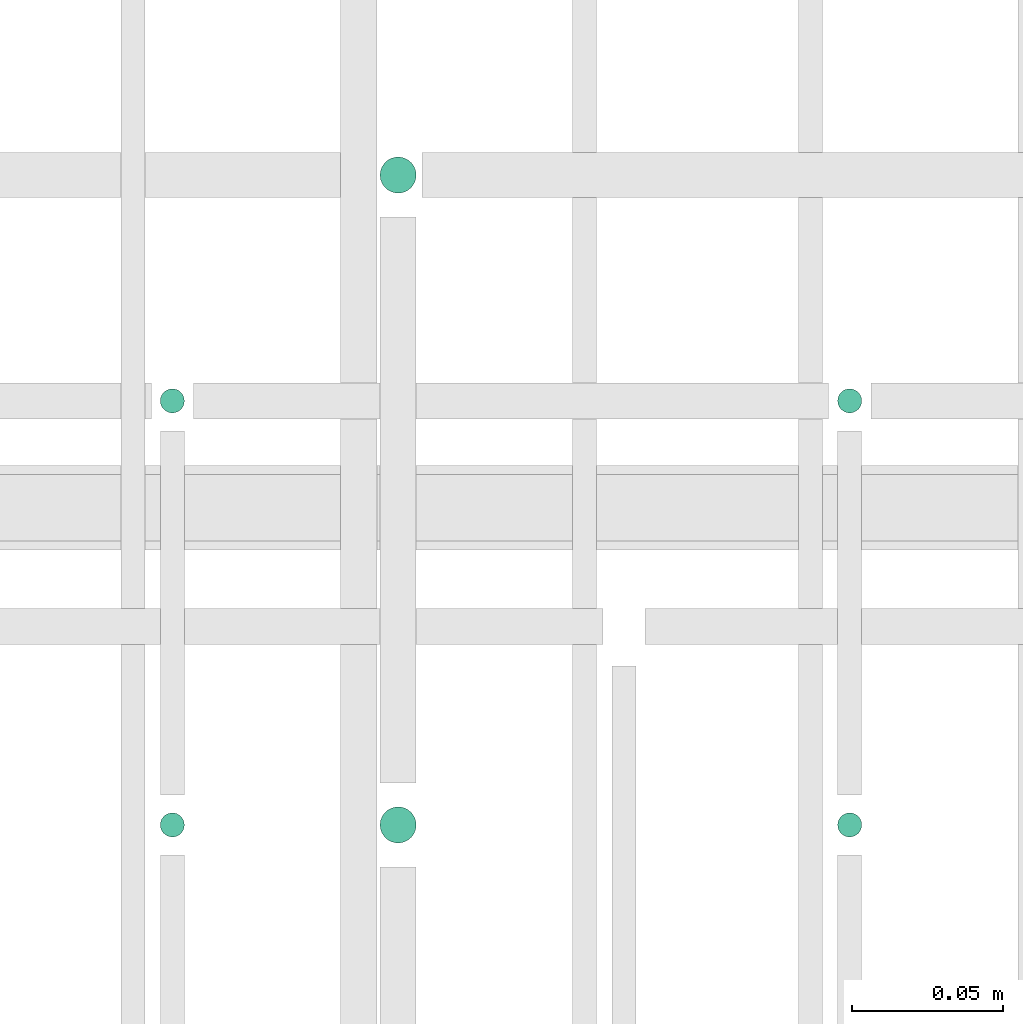
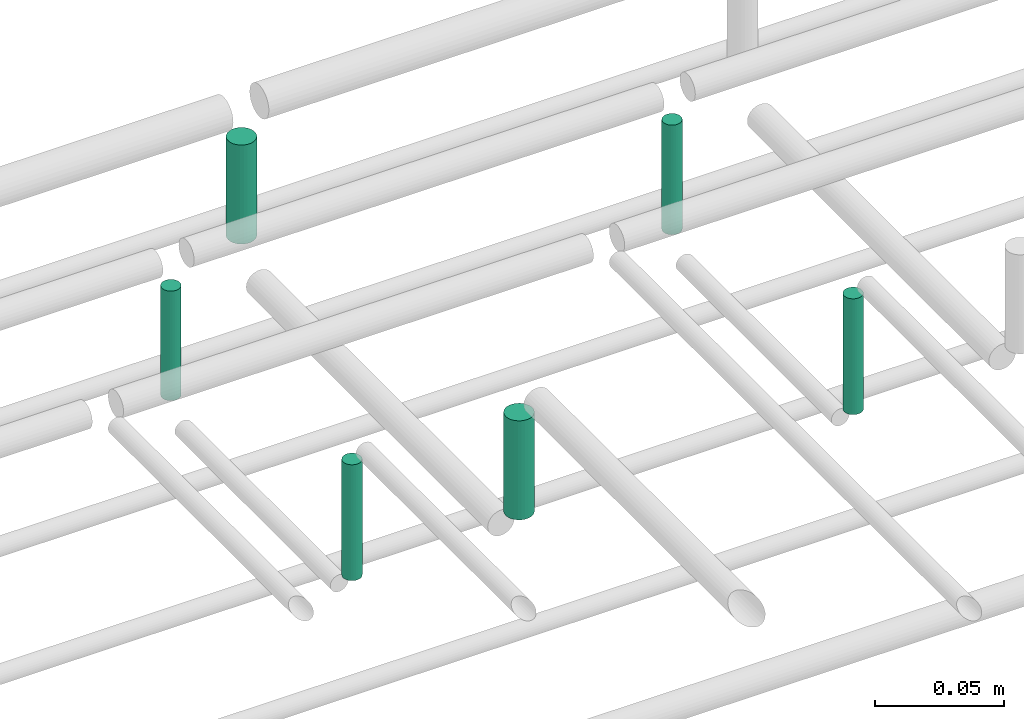
# One storey, part 260 of 331: 6 flow segments.
"""IFC2X3 building model written with IfcOpenShell, lengths in millimetres."""

from ifc_helpers import new_model, entity, si_unit, converted_unit, derived_unit, direction, frame, frame_2d, origin, origin_2d_with_axis, place, context, subcontext, project, spatial, circle, extrude, type_object, element, save


model = new_model("IFC2X3")

# Units and contexts
model_context = context("Model", 3, precision=0.01, world=origin(), true_north=direction((6.12303176911189e-17, 1.0)))
body_context = subcontext(model_context, "Body", "Model", "MODEL_VIEW")
ifc_project = project(units=[si_unit("LENGTHUNIT", "METRE", prefix="MILLI"), si_unit("AREAUNIT", "SQUARE_METRE"), si_unit("VOLUMEUNIT", "CUBIC_METRE"), converted_unit("PLANEANGLEUNIT", "DEGREE", entity("IfcRatioMeasure", 0.0174532925199433), si_unit("PLANEANGLEUNIT", "RADIAN"), dimensions=[0, 0, 0, 0, 0, 0, 0]), si_unit("MASSUNIT", "GRAM", prefix="KILO"), derived_unit("MASSDENSITYUNIT", [(si_unit("MASSUNIT", "GRAM", prefix="KILO"), 1), (si_unit("LENGTHUNIT", "METRE"), -3)]), derived_unit("MOMENTOFINERTIAUNIT", [(si_unit("LENGTHUNIT", "METRE"), 4)]), si_unit("TIMEUNIT", "SECOND"), si_unit("FREQUENCYUNIT", "HERTZ"), si_unit("THERMODYNAMICTEMPERATUREUNIT", "DEGREE_CELSIUS"), derived_unit("THERMALTRANSMITTANCEUNIT", [(si_unit("MASSUNIT", "GRAM", prefix="KILO"), 1), (si_unit("THERMODYNAMICTEMPERATUREUNIT", "KELVIN"), -1), (si_unit("TIMEUNIT", "SECOND"), -3)]), derived_unit("VOLUMETRICFLOWRATEUNIT", [(si_unit("LENGTHUNIT", "METRE"), 3), (si_unit("TIMEUNIT", "SECOND"), -1)]), derived_unit("MASSFLOWRATEUNIT", [(si_unit("MASSUNIT", "GRAM", prefix="KILO"), 1), (si_unit("TIMEUNIT", "SECOND"), -1)]), derived_unit("ROTATIONALFREQUENCYUNIT", [(si_unit("TIMEUNIT", "SECOND"), -1)]), si_unit("ELECTRICCURRENTUNIT", "AMPERE"), si_unit("ELECTRICVOLTAGEUNIT", "VOLT"), si_unit("POWERUNIT", "WATT"), si_unit("FORCEUNIT", "NEWTON", prefix="KILO"), si_unit("ILLUMINANCEUNIT", "LUX"), si_unit("LUMINOUSFLUXUNIT", "LUMEN"), si_unit("LUMINOUSINTENSITYUNIT", "CANDELA"), derived_unit("USERDEFINED", [(si_unit("MASSUNIT", "GRAM", prefix="KILO"), -1), (si_unit("LENGTHUNIT", "METRE"), -2), (si_unit("TIMEUNIT", "SECOND"), 3), (si_unit("LUMINOUSFLUXUNIT", "LUMEN"), 1)]), derived_unit("LINEARVELOCITYUNIT", [(si_unit("LENGTHUNIT", "METRE"), 1), (si_unit("TIMEUNIT", "SECOND"), -1)]), si_unit("PRESSUREUNIT", "PASCAL"), derived_unit("USERDEFINED", [(si_unit("LENGTHUNIT", "METRE"), -2), (si_unit("MASSUNIT", "GRAM", prefix="KILO"), 1), (si_unit("TIMEUNIT", "SECOND"), -2)]), derived_unit("LINEARFORCEUNIT", [(si_unit("MASSUNIT", "GRAM", prefix="KILO"), 1), (si_unit("LENGTHUNIT", "METRE"), 1), (si_unit("TIMEUNIT", "SECOND"), -2), (si_unit("LENGTHUNIT", "METRE"), -1)]), derived_unit("PLANARFORCEUNIT", [(si_unit("MASSUNIT", "GRAM", prefix="KILO"), 1), (si_unit("LENGTHUNIT", "METRE"), 1), (si_unit("TIMEUNIT", "SECOND"), -2), (si_unit("LENGTHUNIT", "METRE"), -2)])], contexts=[model_context])

# Site, building, storey
site_placement = place(None, frame((0.0, -0.00077364408347762, 0.0)))
site = spatial("IfcSite", under=ifc_project, at=site_placement, CompositionType="ELEMENT")
building_placement = place(site_placement, origin())
building = spatial("IfcBuilding", under=site, at=building_placement, CompositionType="ELEMENT")
storey_placement = place(building_placement, origin())
storey = spatial("IfcBuildingStorey", under=building, at=storey_placement, CompositionType="ELEMENT", Elevation=0.0)

# Flow segments
pipe_segment_type = type_object("IfcPipeSegmentType", PredefinedType="NOTDEFINED")
flow_segment_1_placement = place(storey_placement, frame((34478.5132627125, 8084.55397754021, 14485.0)))
element("IfcFlowSegment", 1, at=flow_segment_1_placement, inside=storey, type_object=pipe_segment_type, context=body_context, shape_type="SweptSolid", body=[
    extrude(circle(Radius=4.0, at=frame_2d((0.0, 1.08286712929839e-12), x_axis=(1.0, 0.0))), frame((5.59527223591499, 5.59527223591716, 0.0), z_axis=(0.0, 0.0, 1.0), x_axis=(-1.0, 0.0, 0.0)), (0.0, 0.0, 1.0), 54.9999998911442),
])
flow_segment_2_placement = place(storey_placement, frame((34253.5132627125, 8084.55397754021, 14485.0)))
element("IfcFlowSegment", 2, at=flow_segment_2_placement, inside=storey, type_object=pipe_segment_type, context=body_context, shape_type="SweptSolid", body=[
    extrude(circle(Radius=4.0, at=frame_2d((0.0, -1.08286712929839e-12), x_axis=(1.0, 0.0))), frame((5.59527223591499, 5.59527223591499, 0.0), z_axis=(0.0, 0.0, 1.0), x_axis=(-1.0, 0.0, 0.0)), (0.0, 0.0, 1.0), 54.9999998911442),
])
flow_segment_3_placement = place(storey_placement, frame((34326.5132627125, 8082.55397754021, 14489.0)))
element("IfcFlowSegment", 3, at=flow_segment_3_placement, inside=storey, type_object=pipe_segment_type, context=body_context, shape_type="SweptSolid", body=[
    extrude(circle(Radius=6.0, at=frame_2d((0.0, 1.08286712929839e-12), x_axis=(1.0, 0.0))), frame((7.59527223591454, 7.5952722359167, 0.0), z_axis=(0.0, 0.0, 1.0), x_axis=(-1.0, 0.0, 0.0)), (0.0, 0.0, 1.0), 46.999999891146),
])
flow_segment_4_placement = place(storey_placement, frame((34478.5132627125, 8225.41467161341, 14485.0)))
element("IfcFlowSegment", 4, at=flow_segment_4_placement, inside=storey, type_object=pipe_segment_type, context=body_context, shape_type="SweptSolid", body=[
    extrude(circle(Radius=4.0, at=origin_2d_with_axis()), frame((5.59527223591499, 5.59527223591607, 2.58062397051617e-07)), (0.0, 0.0, 1.0), 51.9993185584609),
])
flow_segment_5_placement = place(storey_placement, frame((34253.5132627125, 8225.41467161342, 14485.0)))
element("IfcFlowSegment", 5, at=flow_segment_5_placement, inside=storey, type_object=pipe_segment_type, context=body_context, shape_type="SweptSolid", body=[
    extrude(circle(Radius=4.0, at=frame_2d((0.0, 1.08286712929839e-12), x_axis=(1.0, 0.0))), frame((5.59527223591499, 5.59527223591499, 2.58062397051617e-07)), (0.0, 0.0, 1.0), 51.9993283614491),
])
flow_segment_6_placement = place(storey_placement, frame((34326.5132590175, 8298.41467161342, 14489.0)))
element("IfcFlowSegment", 6, at=flow_segment_6_placement, inside=storey, type_object=pipe_segment_type, context=body_context, shape_type="SweptSolid", body=[
    extrude(circle(Radius=6.0, at=origin_2d_with_axis()), frame((7.59527593095605, 7.59527223591562, 4.71716413130707e-07)), (0.0, 0.0, 1.0), 46.999074011804),
])

save(model, "model.ifc")
